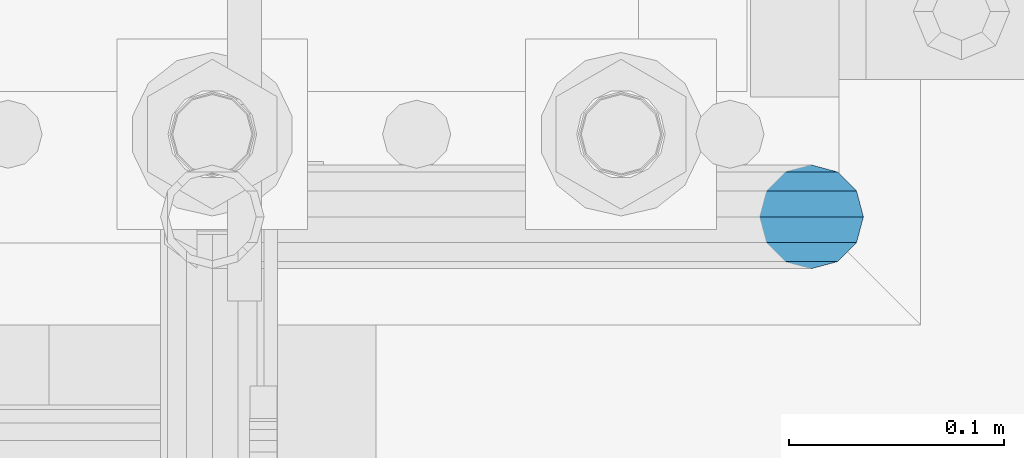
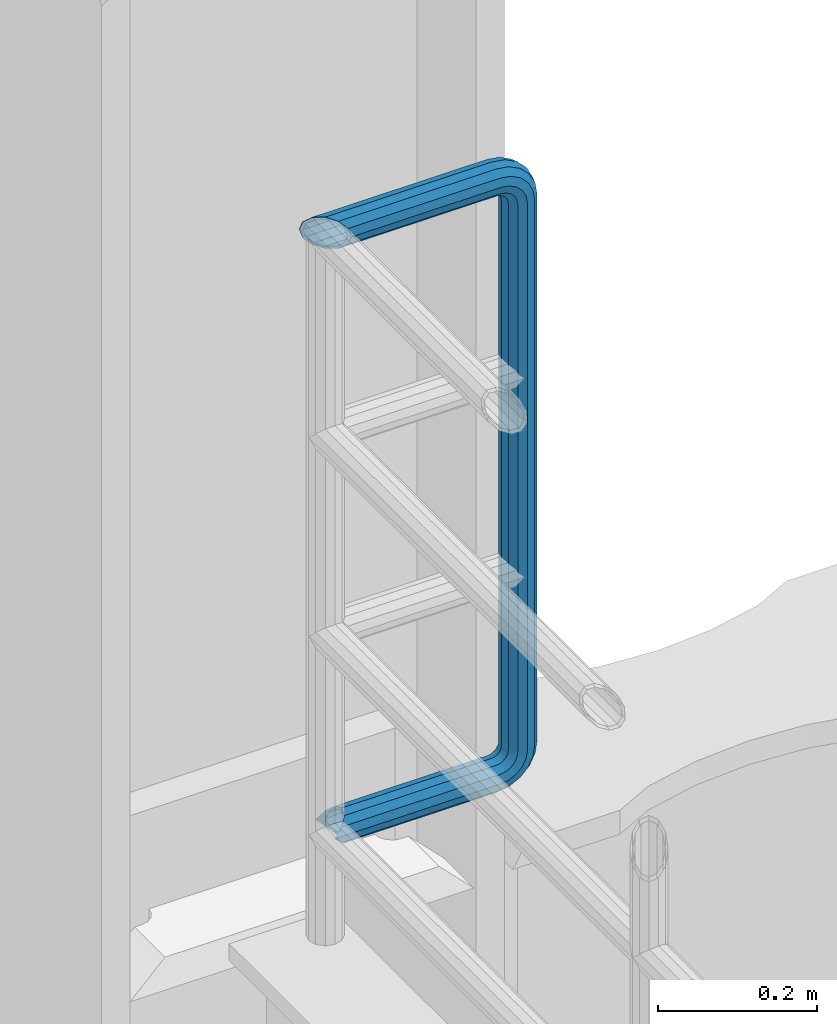
# One storey, part 1056 of 1876: 1 beam, 1 element without a shape of its own.
"""IFC2X3 building model written with IfcOpenShell, lengths in millimetres."""

from ifc_helpers import new_model, si_unit, frame, origin_with_axes, place, context, subcontext, project, spatial, faceted_brep, material, type_object, element, aggregate, save


model = new_model("IFC2X3")

# Units and contexts
model_context = context("Model", 3, precision=1e-05, world=origin_with_axes())
body_context = subcontext(model_context, "Body", "Model", "MODEL_VIEW")
ifc_project = project(units=[si_unit("LENGTHUNIT", "METRE", prefix="MILLI"), si_unit("AREAUNIT", "SQUARE_METRE"), si_unit("VOLUMEUNIT", "CUBIC_METRE"), si_unit("MASSUNIT", "GRAM", prefix="KILO"), si_unit("TIMEUNIT", "SECOND"), si_unit("PLANEANGLEUNIT", "RADIAN"), si_unit("SOLIDANGLEUNIT", "STERADIAN"), si_unit("THERMODYNAMICTEMPERATUREUNIT", "DEGREE_CELSIUS"), si_unit("LUMINOUSINTENSITYUNIT", "LUMEN")], contexts=[model_context])

# Site, building, storey
site_placement = place(None, origin_with_axes())
site = spatial("IfcSite", under=ifc_project, at=site_placement, CompositionType="ELEMENT")
building_placement = place(site_placement, origin_with_axes())
building = spatial("IfcBuilding", under=site, at=building_placement, Name="Undefined", CompositionType="ELEMENT")
storey_placement = place(building_placement, origin_with_axes())
storey = spatial("IfcBuildingStorey", under=building, at=storey_placement, Name="Undefined", CompositionType="ELEMENT", Elevation=0.0)

# Assembly, beam
assembly_placement = place(storey_placement, origin_with_axes())
assembly = element("IfcElementAssembly", 1, at=assembly_placement, inside=storey, Name="RAIL", AssemblyPlace="NOTDEFINED", PredefinedType="RIGID_FRAME")
ifc_material = material()
beam_type = type_object("IfcBeamType", Name="PIPE1-1/2SCH40", PredefinedType="NOTDEFINED")
beam_placement = place(assembly_placement, frame((-3.18323145620525e-12, 13499.7063, 9229.725), z_axis=(0.0, 0.0, 1.0), x_axis=(1.0, 0.0, 0.0)))
beam = element("IfcBeam", 2, at=beam_placement, type_object=beam_type, material=ifc_material, Name="RAIL", ObjectType="PIPE1-1/2SCH40", context=body_context, shape_type="Brep", body=[
    faceted_brep([(1.20714750983051e-12, 24.1299999999974, -914.399963378906), (12.0650000000014, 20.8971929933159, -926.464963378905), (12.0650000000014, 20.8971929933177, -902.334963378908), (12.0650000000014, -20.8971929933195, -902.334963378908), (12.0650000000014, -20.8971929933195, -926.464963378905), (1.52133659548828e-12, -24.130000000001, -914.399963378906), (20.8971929933199, -12.0650000000023, -893.502770385589), (20.8971929933199, -12.0650000000005, -898.533841947723), (15.2545715621378, -17.7076214311819, -904.176463378906), (12.5151929933181, -20.4470000000019, -914.399963378906), (15.2545715621376, -17.7076214311819, -924.623463378906), (20.8971929933199, -12.0650000000005, -930.26608481009), (20.8971929933199, -12.0650000000023, -935.297156372224), (24.1300000000014, -1.81898940354586e-12, -934.846963378906), (24.1300000000014, -1.81898940354586e-12, -938.529963378907), (21.3906214311813, -10.2235000000019, -932.107584810088), (21.3906214311823, 10.2234999999982, -932.107584810088), (20.8971929933199, 12.0650000000005, -930.266084810086), (20.8971929933199, 12.0649999999987, -935.297156372224), (15.2545715621413, 17.7076214311783, -924.623463378906), (12.5151929933216, 20.4469999999983, -914.399963378906), (15.2545715621411, 17.7076214311783, -904.176463378906), (20.8971929933199, 12.0650000000005, -898.533841947727), (20.8971929933199, 12.0649999999987, -893.502770385589), (21.3906214311822, 10.2234999999982, -896.692341947724), (24.1300000000014, 0.0, -893.952963378906), (24.1300000000014, 0.0, -890.269963378905), (21.3906214311814, -10.2235000000019, -896.692341947724), (241.299995422363, -20.8971929933177, 12.0649999999987), (241.299995422363, -24.1299999999992, 0.0), (253.073542436527, -24.1299999999992, -1.86474665447167), (256.801832473661, -20.8971929933177, 9.60975021462946), (241.299995422363, -12.0650000000005, 20.8971929933177), (259.531130206197, -12.0650000000005, 18.0096649141014), (241.299995422363, 0.0, 24.130000000001), (260.530122510796, 0.0, 21.084247083727), (241.299995422363, 12.0650000000005, 20.8971929933177), (259.531130206197, 12.0650000000005, 18.0096649141014), (241.299995422363, 20.8971929933177, 12.0649999999987), (256.801832473661, 20.8971929933177, 9.60975021462946), (241.299995422363, 24.1299999999992, 0.0), (253.073542436527, 24.1299999999992, -1.86474665447167), (241.299995422363, 20.8971929933177, -12.0649999999987), (249.345252399393, 20.8971929933177, -13.3392435235728), (241.299995422363, 12.0650000000005, -20.8971929933177), (246.615954666858, 12.0650000000005, -21.7391582230448), (241.299995422363, 0.0, -24.130000000001), (245.616962362259, 0.0, -24.8137403926739), (241.299995422363, -12.0650000000005, -20.8971929933177), (246.615954666858, -12.0650000000005, -21.7391582230448), (241.299995422363, -20.8971929933177, -12.0649999999987), (249.345252399393, -20.8971929933177, -13.3392435235728), (267.334993896485, 20.8971929933177, -38.0999984741211), (279.399993896485, 24.1299999999992, -38.0999984741211), (279.399993896484, 24.1299999999992, -876.299964904785), (267.334993896484, 20.8971929933177, -876.299964904785), (291.464993896486, 20.8971929933177, -38.0999984741211), (291.464993896484, 20.8971929933177, -876.299964904785), (300.297186889804, 12.0650000000005, -38.0999984741211), (300.297186889803, 12.0650000000005, -876.299964904785), (303.529993896486, 0.0, -38.0999984741211), (303.529993896484, 0.0, -876.299964904785), (300.297186889804, -12.0650000000005, -38.0999984741211), (300.297186889803, -12.0650000000005, -876.299964904785), (291.464993896486, -20.8971929933177, -38.0999984741211), (291.464993896484, -20.8971929933177, -876.299964904785), (279.399993896484, -24.1299999999992, -38.0999984741211), (279.399993896484, -24.1299999999992, -876.299964904785), (267.334993896485, -20.8971929933177, -38.0999984741211), (267.334993896484, -20.8971929933177, -876.299964904785), (258.502800903167, -12.0650000000005, -38.0999984741211), (258.502800903166, -12.0650000000005, -876.299964904785), (255.269993896485, 0.0, -38.0999984741211), (255.269993896484, 0.0, -876.299964904785), (258.502800903167, 12.0650000000005, -38.0999984741211), (258.502800903166, 12.0650000000005, -876.299964904785), (257.660835673438, 12.0650000000005, -881.615924149282), (254.586253503809, 0.0, -880.616931844681), (257.660835673438, -12.0650000000005, -881.615924149282), (266.06075037291, -20.8971929933177, -884.345221881817), (277.535247242011, -24.130000000001, -888.073511918952), (289.009744111112, -20.8971929933195, -891.801801956084), (297.409658810584, -12.0650000000005, -894.531099688622), (300.484240980214, 0.0, -895.53009199322), (297.409658810584, 12.0650000000005, -894.531099688622), (289.009744111112, 20.8971929933177, -891.801801956084), (277.535247242011, 24.1299999999992, -888.073511918952), (266.06075037291, 20.8971929933177, -884.345221881817), (241.299995422364, -1.81898940354586e-12, -938.529963378911), (241.299995422364, -12.0650000000005, -935.297156372228), (241.299995422364, -20.8971929933195, -926.464963378909), (241.299995422363, -24.130000000001, -914.399963378906), (241.299995422363, -20.8971929933195, -902.334963378908), (241.299995422363, -12.0650000000005, -893.502770385589), (241.299995422363, 0.0, -890.269963378909), (241.299995422364, 20.8971929933177, -926.464963378909), (241.299995422364, 12.0649999999987, -935.297156372228), (241.299995422364, 24.1299999999992, -914.39996337891), (241.299995422363, 20.8971929933177, -902.334963378908), (241.299995422363, 12.0649999999987, -893.502770385589), (260.530122510801, 0.0, -935.484210462637), (259.531130206202, 12.0649999999987, -932.409628293008), (259.531130206201, -12.0650000000005, -932.409628293008), (256.801832473666, -20.8971929933195, -924.009713593536), (253.07354243653, -24.130000000001, -912.535216724435), (249.345252399395, -20.8971929933195, -901.060719855333), (246.615954666859, -12.0650000000005, -892.660805155861), (245.61696236226, 0.0, -889.586222986232), (246.615954666859, 12.0649999999987, -892.660805155861), (249.345252399395, 20.8971929933177, -901.060719855333), (253.07354243653, 24.1299999999992, -912.535216724435), (256.801832473666, 20.8971929933177, -924.009713593536), (275.977674493594, 12.0649999999987, -924.029695422345), (270.786241706733, 20.8971929933177, -916.884301193139), (277.877870775644, 0.0, -926.645091230272), (275.977674493608, -12.0650000000005, -924.029695422334), (270.786241706733, -20.8971929933195, -916.884301193139), (263.694612637823, -24.130000000001, -907.123511156005), (256.602983568912, -20.8971929933195, -897.362721118872), (251.411550782037, -12.0650000000005, -890.21732688968), (249.511354500001, 0.0, -887.601931081743), (251.411550782037, 12.0650000000005, -890.21732688968), (256.602983568912, 20.8971929933177, -897.362721118872), (263.694612637823, 24.1299999999992, -907.123511156005), (281.884331710718, 20.8971929933177, -905.786211189152), (272.123541673585, 24.1299999999992, -898.694582120243), (289.029725939912, 12.0650000000005, -910.977643976028), (291.645121747852, 0.0, -912.877840258065), (289.029725939912, -12.0650000000005, -910.977643976028), (281.884331710718, -20.8971929933195, -905.786211189152), (272.123541673585, -24.130000000001, -898.694582120243), (262.362751636451, -20.8971929933195, -891.602953051333), (255.217357407258, -12.0650000000005, -886.411520264461), (252.601961599318, 0.0, -884.511323982424), (255.217357407258, 12.0650000000005, -886.411520264461), (262.362751636451, 20.8971929933177, -891.602953051333), (266.060750372911, 20.8971929933177, -30.0547414970897), (257.660835673439, 12.0650000000005, -32.7840392296275), (277.535247242011, 24.1299999999992, -26.3264514599541), (289.009744111112, 20.8971929933177, -22.5981614228222), (297.409658810584, 12.0650000000005, -19.8688636902843), (300.484240980213, 0.0, -18.8698713856866), (297.409658810584, -12.0650000000005, -19.8688636902843), (289.009744111112, -20.8971929933177, -22.5981614228222), (277.535247242011, -24.1299999999992, -26.3264514599541), (266.060750372911, -20.8971929933177, -30.0547414970897), (257.660835673439, -12.0650000000005, -32.7840392296275), (254.58625350381, 0.0, -33.7830315342253), (255.217357407257, 12.0650000000005, -27.9884431144455), (252.601961599318, 0.0, -29.8886393964822), (262.362751636451, 20.8971929933177, -22.7970103275729), (272.123541673583, 24.1299999999992, -15.7053812586601), (281.884331710716, 20.8971929933177, -8.61375218975081), (289.029725939909, 12.0650000000005, -3.42231940287456), (291.645121747848, 0.0, -1.52212312084157), (289.029725939909, -12.0650000000005, -3.42231940287456), (281.884331710716, -20.8971929933177, -8.61375218975081), (272.123541673583, -24.1299999999992, -15.7053812586601), (262.362751636451, -20.8971929933177, -22.7970103275729), (255.217357407257, -12.0650000000005, -27.9884431144455), (249.511354500002, 0.0, -26.7980322971671), (251.411550782037, -12.0650000000005, -24.1826364892258), (251.411550782037, 12.0650000000005, -24.1826364892258), (256.602983568912, 20.8971929933177, -17.037242260034), (263.694612637822, 24.1299999999992, -7.27645222290084), (270.786241706732, 20.8971929933177, 2.48433781423228), (275.977674493607, 12.0650000000005, 9.62973204342416), (277.877870775642, 0.0, 12.2451278513654), (275.977674493607, -12.0650000000005, 9.62973204342416), (270.786241706732, -20.8971929933177, 2.48433781423228), (263.694612637822, -24.1299999999992, -7.27645222290084), (256.602983568912, -20.8971929933177, -17.037242260034), (24.1299999999854, -24.1299999999992, 0.0), (20.8971929933039, -20.8971929933177, -12.0649999999987), (12.0649999999854, -12.0650000000005, -20.8971929933177), (20.8971929933249, -12.0650000000005, -20.8971929933177), (16.4810997545745, -16.4810997545883, -16.48109323873), (24.1300000000063, 0.0, -24.130000000001), (-1.45519152283669e-11, 0.0, -24.130000000001), (20.8971929933249, 12.0650000000005, -20.8971929933177), (-12.0650000000145, 12.0650000000005, -20.8971929933177), (-20.897192993333, 20.8971929933177, -12.0649999999987), (-12.0649999999986, 20.8971929933177, -12.0649999999987), (12.0650000000064, 20.8971929933177, -12.0649999999987), (-16.481093238746, 16.4810932387318, -16.4810997545865), (0.0, 24.1299999999992, 0.0), (-24.1300000000145, 24.1299999999992, 0.0), (-20.897192993333, 20.8971929933177, 12.0649999999987), (-12.0650000000145, 12.0650000000005, 20.8971929933177), (-1.45519152283669e-11, 0.0, 24.130000000001), (12.0649999999854, -12.0650000000005, 20.8971929933177), (20.8971929933039, -20.8971929933177, 12.0649999999987), (241.299995422363, -17.7076214311801, 10.2235000000001), (241.299995422363, -20.4470000000001, 0.0), (20.4469999999854, -20.4470000000001, 0.0), (17.7076214311658, -17.7076214311801, 10.2235000000001), (241.299995422363, 0.0, 20.4470000000001), (241.299995422363, -10.2235000000001, 17.7076214311819), (10.2234999999854, -10.2235000000001, 17.7076214311819), (-1.45519152283669e-11, 0.0, 20.4470000000001), (241.299995422363, 10.2235000000001, 17.7076214311819), (-10.2235000000145, 10.2235000000001, 17.7076214311819), (241.299995422363, 17.7076214311801, 10.2235000000001), (-17.7076214311949, 17.7076214311801, 10.2235000000001), (241.299995422363, 20.4470000000001, 0.0), (-20.4470000000145, 20.4470000000001, 0.0), (241.299995422363, 17.7076214311801, -10.2235000000001), (-17.7076214311949, 17.7076214311801, -10.2235000000001), (241.299995422363, 10.2235000000001, -17.7076214311819), (-10.2235000000145, 10.2235000000001, -17.7076214311819), (241.299995422363, 0.0, -20.4470000000001), (-1.45519152283669e-11, 0.0, -20.4470000000001), (241.299995422363, -10.2235000000001, -17.7076214311819), (10.2234999999854, -10.2235000000001, -17.7076214311819), (241.299995422363, -17.7076214311801, -10.2235000000001), (17.7076214311658, -17.7076214311801, -10.2235000000001), (258.545498388721, -10.2235000000001, 14.9762020957387), (256.23277767852, -17.7076214311801, 7.85837963987069), (253.073542436527, -20.4470000000001, -1.86474665447167), (249.914307194535, -17.7076214311801, -11.5878729488177), (247.601586484334, -10.2235000000001, -18.7056954046857), (246.755071952542, 0.0, -21.31099924316), (247.601586484334, 10.2235000000001, -18.7056954046857), (249.914307194535, 17.7076214311801, -11.5878729488177), (253.073542436527, 20.4470000000001, -1.86474665447167), (256.23277767852, 17.7076214311801, 7.85837963987069), (258.545498388721, 10.2235000000001, 14.9762020957387), (259.392012920513, 0.0, 17.5815059342131), (275.713057691449, 0.0, 9.26551826108334), (274.10289136825, -10.2235000000001, 7.04931444488102), (274.10289136825, 10.2235000000001, 7.04931444488102), (269.703835164635, 17.7076214311801, 0.994533019089431), (263.694612637822, 20.4470000000001, -7.27645222290084), (257.685390111009, 17.7076214311801, -15.5474374648911), (253.286333907394, 10.2235000000001, -21.6022188906827), (251.676167584195, 0.0, -23.818422706885), (253.286333907394, -10.2235000000001, -21.6022188906827), (257.685390111009, -17.7076214311801, -15.5474374648911), (263.694612637822, -20.4470000000001, -7.27645222290084), (269.703835164635, -17.7076214311801, 0.994533019089431), (286.449308341364, -10.2235000000001, -5.29710252823133), (280.394526915574, -17.7076214311801, -9.69615873184739), (288.665512157566, 0.0, -3.68693620503473), (286.449308341364, 10.2235000000001, -5.29710252823133), (280.394526915574, 17.7076214311801, -9.69615873184739), (272.123541673583, 20.4470000000001, -15.7053812586601), (263.852556431592, 17.7076214311801, -21.7146037854764), (257.797775005802, 10.2235000000001, -26.1136599890888), (255.581571189601, 0.0, -27.723826312289), (257.797775005802, -10.2235000000001, -26.1136599890888), (263.852556431592, -17.7076214311801, -21.7146037854764), (272.123541673583, -20.4470000000001, -15.7053812586601), (287.258373536355, -17.7076214311801, -23.1672162179639), (277.535247242011, -20.4470000000001, -26.3264514599541), (294.376195992223, -10.2235000000001, -20.8544955077632), (296.981499830698, 0.0, -20.00798097597), (294.376195992223, 10.2235000000001, -20.8544955077632), (287.258373536355, 17.7076214311801, -23.1672162179639), (277.535247242011, 20.4470000000001, -26.3264514599541), (267.812120947668, 17.7076214311801, -29.485686701948), (260.6942984918, 10.2235000000001, -31.7984074121487), (258.088994653325, 0.0, -32.6449219439419), (260.6942984918, -10.2235000000001, -31.7984074121487), (267.812120947668, -17.7076214311801, -29.485686701948), (279.399993896484, -20.4470000000001, -38.0999984741211), (269.176493896485, -17.7076214311801, -38.0999984741211), (289.623493896486, -17.7076214311801, -38.0999984741211), (297.107615327666, -10.2235000000001, -38.0999984741211), (299.846993896486, 0.0, -38.0999984741211), (297.107615327666, 10.2235000000001, -38.0999984741211), (289.623493896486, 17.7076214311801, -38.0999984741211), (279.399993896485, 20.4470000000001, -38.0999984741211), (269.176493896485, 17.7076214311801, -38.0999984741211), (261.692372465305, 10.2235000000001, -38.0999984741211), (258.952993896485, 0.0, -38.0999984741211), (261.692372465305, -10.2235000000001, -38.0999984741211), (269.176493896484, -17.7076214311801, -876.299964904785), (261.692372465304, -10.2235000000001, -876.299964904785), (258.952993896484, 0.0, -876.299964904785), (261.692372465304, 10.2235000000001, -876.299964904785), (269.176493896484, 17.7076214311801, -876.299964904785), (279.399993896484, 20.4470000000001, -876.299964904785), (289.623493896484, 17.7076214311801, -876.299964904785), (297.107615327665, 10.2235000000001, -876.299964904785), (299.846993896484, 0.0, -876.299964904785), (297.107615327665, -10.2235000000001, -876.299964904785), (289.623493896484, -17.7076214311801, -876.299964904785), (279.399993896484, -20.4470000000001, -876.299964904785), (277.535247242011, -20.4470000000001, -888.073511918952), (267.812120947667, -17.7076214311801, -884.914276676958), (260.694298491799, -10.2235000000001, -882.601555966758), (258.088994653324, 0.0, -881.755041434964), (260.694298491799, 10.2235000000001, -882.601555966758), (267.812120947668, 17.7076214311801, -884.914276676958), (277.535247242011, 20.4470000000001, -888.073511918952), (287.258373536355, 17.7076214311801, -891.232747160942), (294.376195992223, 10.2235000000001, -893.545467871143), (296.981499830699, 0.0, -894.391982402936), (294.376195992223, -10.2235000000001, -893.545467871143), (287.258373536355, -17.7076214311801, -891.232747160942), (280.394526915577, -17.7076214311801, -904.703804647055), (272.123541673585, -20.4470000000001, -898.694582120243), (286.449308341367, -10.2235000000001, -909.102860850671), (288.665512157569, 0.0, -910.713027173868), (286.449308341367, 10.2235000000001, -909.102860850671), (280.394526915577, 17.7076214311801, -904.703804647055), (272.123541673585, 20.4470000000001, -898.694582120243), (263.852556431593, 17.7076214311801, -892.68535959343), (257.797775005802, 10.2235000000001, -888.286303389817), (255.581571189601, 0.0, -886.676137066617), (257.797775005802, -10.2235000000001, -888.286303389817), (263.852556431593, -17.7076214311801, -892.68535959343), (263.694612637823, -20.4470000000001, -907.123511156005), (257.685390111009, -17.7076214311801, -898.852525914015), (269.703835164636, -17.7076214311801, -915.394496397999), (274.102891368238, -10.2235000000001, -921.449277823798), (275.71305769145, 0.0, -923.66548163999), (274.102891368251, 10.2235000000001, -921.449277823787), (269.703835164636, 17.7076214311801, -915.394496397999), (263.694612637823, 20.4470000000001, -907.123511156005), (257.685390111009, 17.7076214311801, -898.852525914015), (253.286333907394, 10.2235000000001, -892.797744488227), (251.676167584195, 0.0, -890.581540672025), (253.286333907394, -10.2235000000001, -892.797744488227), (249.914307194537, -17.7076214311801, -902.812090430092), (247.601586484335, -10.2235000000001, -895.694267974224), (253.07354243653, -20.4470000000001, -912.535216724435), (256.232777678524, -17.7076214311819, -922.258343018777), (258.545498388725, -10.2235000000001, -929.376165474645), (259.392012920517, 0.0, -931.981469313119), (258.545498388725, 10.2235000000001, -929.376165474645), (256.232777678524, 17.7076214311801, -922.258343018777), (253.07354243653, 20.4470000000001, -912.535216724435), (249.914307194537, 17.7076214311801, -902.812090430092), (247.601586484335, 10.2235000000001, -895.694267974224), (246.755071952543, 0.0, -893.088964135746), (241.299995422363, -10.2235000000001, -896.692341947728), (241.299995422363, 0.0, -893.95296337891), (241.299995422363, -17.7076214311819, -904.17646337891), (241.299995422363, -20.4470000000001, -914.399963378906), (241.299995422364, -17.7076214311819, -924.62346337891), (241.299995422364, -10.2235000000001, -932.107584810088), (241.299995422364, -1.81898940354586e-12, -934.84696337891), (241.299995422364, 10.2234999999982, -932.107584810088), (241.299995422364, 17.7076214311801, -924.62346337891), (241.299995422364, 20.4470000000001, -914.39996337891), (241.299995422363, 17.7076214311801, -904.17646337891), (241.299995422363, 10.2235000000001, -896.692341947728)], [[[0, 1, 2]], [[3, 4, 5]], [[6, 7, 8, 9, 10, 11, 12, 4, 3]], [[13, 14, 12, 11, 15]], [[16, 17, 18, 14, 13]], [[2, 1, 18, 17, 19, 20, 21, 22, 23]], [[23, 22, 24, 25, 26]], [[26, 25, 27, 7, 6]], [[28, 29, 30, 31]], [[32, 28, 31, 33]], [[34, 32, 33, 35]], [[36, 34, 35, 37]], [[38, 36, 37, 39]], [[40, 38, 39, 41]], [[42, 40, 41, 43]], [[44, 42, 43, 45]], [[46, 44, 45, 47]], [[48, 46, 47, 49]], [[50, 48, 49, 51]], [[52, 53, 54, 55]], [[53, 56, 57, 54]], [[56, 58, 59, 57]], [[58, 60, 61, 59]], [[60, 62, 63, 61]], [[62, 64, 65, 63]], [[64, 66, 67, 65]], [[66, 68, 69, 67]], [[68, 70, 71, 69]], [[70, 72, 73, 71]], [[72, 74, 75, 73]], [[73, 75, 76, 77]], [[71, 73, 77, 78]], [[69, 71, 78, 79]], [[67, 69, 79, 80]], [[65, 67, 80, 81]], [[63, 65, 81, 82]], [[61, 63, 82, 83]], [[59, 61, 83, 84]], [[57, 59, 84, 85]], [[54, 57, 85, 86]], [[55, 54, 86, 87]], [[88, 89, 12, 14]], [[89, 90, 4, 12]], [[90, 91, 5, 4]], [[91, 92, 3, 5]], [[92, 93, 6, 3]], [[93, 94, 26, 6]], [[95, 96, 18, 1]], [[97, 95, 1, 0]], [[98, 97, 0, 2]], [[99, 98, 2, 23]], [[94, 99, 23, 26]], [[96, 88, 14, 18]], [[100, 88, 96, 101]], [[102, 89, 88, 100]], [[103, 90, 89, 102]], [[104, 91, 90, 103]], [[105, 92, 91, 104]], [[106, 93, 92, 105]], [[107, 94, 93, 106]], [[108, 99, 94, 107]], [[109, 98, 99, 108]], [[110, 97, 98, 109]], [[111, 95, 97, 110]], [[101, 96, 95, 111]], [[112, 101, 111, 113]], [[114, 100, 101, 112]], [[115, 102, 100, 114]], [[116, 103, 102, 115]], [[117, 104, 103, 116]], [[118, 105, 104, 117]], [[119, 106, 105, 118]], [[120, 107, 106, 119]], [[121, 108, 107, 120]], [[122, 109, 108, 121]], [[123, 110, 109, 122]], [[113, 111, 110, 123]], [[124, 113, 123, 125]], [[126, 112, 113, 124]], [[127, 114, 112, 126]], [[128, 115, 114, 127]], [[129, 116, 115, 128]], [[130, 117, 116, 129]], [[131, 118, 117, 130]], [[132, 119, 118, 131]], [[133, 120, 119, 132]], [[134, 121, 120, 133]], [[135, 122, 121, 134]], [[125, 123, 122, 135]], [[86, 125, 135, 87]], [[85, 124, 125, 86]], [[84, 126, 124, 85]], [[83, 127, 126, 84]], [[82, 128, 127, 83]], [[81, 129, 128, 82]], [[80, 130, 129, 81]], [[79, 131, 130, 80]], [[78, 132, 131, 79]], [[77, 133, 132, 78]], [[76, 134, 133, 77]], [[87, 135, 134, 76]], [[75, 55, 87, 76]], [[74, 52, 55, 75]], [[136, 52, 74, 137]], [[138, 53, 52, 136]], [[139, 56, 53, 138]], [[140, 58, 56, 139]], [[141, 60, 58, 140]], [[142, 62, 60, 141]], [[143, 64, 62, 142]], [[144, 66, 64, 143]], [[145, 68, 66, 144]], [[146, 70, 68, 145]], [[147, 72, 70, 146]], [[137, 74, 72, 147]], [[148, 137, 147, 149]], [[150, 136, 137, 148]], [[151, 138, 136, 150]], [[152, 139, 138, 151]], [[153, 140, 139, 152]], [[154, 141, 140, 153]], [[155, 142, 141, 154]], [[156, 143, 142, 155]], [[157, 144, 143, 156]], [[158, 145, 144, 157]], [[159, 146, 145, 158]], [[149, 147, 146, 159]], [[160, 149, 159, 161]], [[162, 148, 149, 160]], [[163, 150, 148, 162]], [[164, 151, 150, 163]], [[165, 152, 151, 164]], [[166, 153, 152, 165]], [[167, 154, 153, 166]], [[168, 155, 154, 167]], [[169, 156, 155, 168]], [[170, 157, 156, 169]], [[171, 158, 157, 170]], [[161, 159, 158, 171]], [[49, 161, 171, 51]], [[47, 160, 161, 49]], [[45, 162, 160, 47]], [[43, 163, 162, 45]], [[41, 164, 163, 43]], [[39, 165, 164, 41]], [[37, 166, 165, 39]], [[35, 167, 166, 37]], [[33, 168, 167, 35]], [[31, 169, 168, 33]], [[30, 170, 169, 31]], [[51, 171, 170, 30]], [[29, 50, 51, 30]], [[50, 29, 172, 173]], [[174, 175, 48, 50, 173, 176]], [[177, 46, 48, 175, 174, 178]], [[179, 44, 46, 177, 178, 180]], [[181, 182, 183, 42, 44, 179, 180, 184]], [[185, 40, 42, 183, 182, 181, 186]], [[38, 40, 185, 186, 187]], [[36, 38, 187, 188]], [[34, 36, 188, 189]], [[32, 34, 189, 190]], [[28, 32, 190, 191]], [[29, 28, 191, 172]], [[192, 193, 194, 195]], [[196, 197, 198, 199]], [[200, 196, 199, 201]], [[202, 200, 201, 203]], [[204, 202, 203, 205]], [[206, 204, 205, 207]], [[208, 206, 207, 209]], [[210, 208, 209, 211]], [[212, 210, 211, 213]], [[214, 212, 213, 215]], [[193, 214, 215, 194]], [[190, 189, 188, 187, 186, 181, 184, 180, 178, 174, 176, 173, 172, 191], [213, 211, 209, 207, 205, 203, 201, 199, 198, 195, 194, 215]], [[197, 192, 195, 198]], [[192, 197, 216, 217]], [[193, 192, 217, 218]], [[214, 193, 218, 219]], [[212, 214, 219, 220]], [[210, 212, 220, 221]], [[208, 210, 221, 222]], [[206, 208, 222, 223]], [[204, 206, 223, 224]], [[202, 204, 224, 225]], [[200, 202, 225, 226]], [[196, 200, 226, 227]], [[197, 196, 227, 216]], [[227, 228, 229, 216]], [[226, 230, 228, 227]], [[225, 231, 230, 226]], [[224, 232, 231, 225]], [[223, 233, 232, 224]], [[222, 234, 233, 223]], [[221, 235, 234, 222]], [[220, 236, 235, 221]], [[219, 237, 236, 220]], [[218, 238, 237, 219]], [[217, 239, 238, 218]], [[216, 229, 239, 217]], [[229, 240, 241, 239]], [[228, 242, 240, 229]], [[230, 243, 242, 228]], [[231, 244, 243, 230]], [[232, 245, 244, 231]], [[233, 246, 245, 232]], [[234, 247, 246, 233]], [[235, 248, 247, 234]], [[236, 249, 248, 235]], [[237, 250, 249, 236]], [[238, 251, 250, 237]], [[239, 241, 251, 238]], [[241, 252, 253, 251]], [[240, 254, 252, 241]], [[242, 255, 254, 240]], [[243, 256, 255, 242]], [[244, 257, 256, 243]], [[245, 258, 257, 244]], [[246, 259, 258, 245]], [[247, 260, 259, 246]], [[248, 261, 260, 247]], [[249, 262, 261, 248]], [[250, 263, 262, 249]], [[251, 253, 263, 250]], [[253, 264, 265, 263]], [[252, 266, 264, 253]], [[254, 267, 266, 252]], [[255, 268, 267, 254]], [[256, 269, 268, 255]], [[257, 270, 269, 256]], [[258, 271, 270, 257]], [[259, 272, 271, 258]], [[260, 273, 272, 259]], [[261, 274, 273, 260]], [[262, 275, 274, 261]], [[263, 265, 275, 262]], [[275, 265, 276, 277]], [[274, 275, 277, 278]], [[273, 274, 278, 279]], [[272, 273, 279, 280]], [[271, 272, 280, 281]], [[270, 271, 281, 282]], [[269, 270, 282, 283]], [[268, 269, 283, 284]], [[267, 268, 284, 285]], [[266, 267, 285, 286]], [[264, 266, 286, 287]], [[265, 264, 287, 276]], [[276, 287, 288, 289]], [[277, 276, 289, 290]], [[278, 277, 290, 291]], [[279, 278, 291, 292]], [[280, 279, 292, 293]], [[281, 280, 293, 294]], [[282, 281, 294, 295]], [[283, 282, 295, 296]], [[284, 283, 296, 297]], [[285, 284, 297, 298]], [[286, 285, 298, 299]], [[287, 286, 299, 288]], [[299, 300, 301, 288]], [[298, 302, 300, 299]], [[297, 303, 302, 298]], [[296, 304, 303, 297]], [[295, 305, 304, 296]], [[294, 306, 305, 295]], [[293, 307, 306, 294]], [[292, 308, 307, 293]], [[291, 309, 308, 292]], [[290, 310, 309, 291]], [[289, 311, 310, 290]], [[288, 301, 311, 289]], [[301, 312, 313, 311]], [[300, 314, 312, 301]], [[302, 315, 314, 300]], [[303, 316, 315, 302]], [[304, 317, 316, 303]], [[305, 318, 317, 304]], [[306, 319, 318, 305]], [[307, 320, 319, 306]], [[308, 321, 320, 307]], [[309, 322, 321, 308]], [[310, 323, 322, 309]], [[311, 313, 323, 310]], [[313, 324, 325, 323]], [[312, 326, 324, 313]], [[314, 327, 326, 312]], [[315, 328, 327, 314]], [[316, 329, 328, 315]], [[317, 330, 329, 316]], [[318, 331, 330, 317]], [[319, 332, 331, 318]], [[320, 333, 332, 319]], [[321, 334, 333, 320]], [[322, 335, 334, 321]], [[323, 325, 335, 322]], [[325, 336, 337, 335]], [[324, 338, 336, 325]], [[326, 339, 338, 324]], [[327, 340, 339, 326]], [[328, 341, 340, 327]], [[329, 342, 341, 328]], [[330, 343, 342, 329]], [[331, 344, 343, 330]], [[332, 345, 344, 331]], [[333, 346, 345, 332]], [[334, 347, 346, 333]], [[335, 337, 347, 334]], [[347, 337, 25, 24]], [[21, 346, 347, 24, 22]], [[345, 346, 21, 20]], [[344, 345, 20, 19]], [[343, 344, 19, 17, 16]], [[342, 343, 16, 13]], [[341, 342, 13, 15]], [[10, 340, 341, 15, 11]], [[339, 340, 10, 9]], [[338, 339, 9, 8]], [[336, 338, 8, 7, 27]], [[337, 336, 27, 25]]]),
])
aggregate(assembly, [beam])

save(model, "model.ifc")
